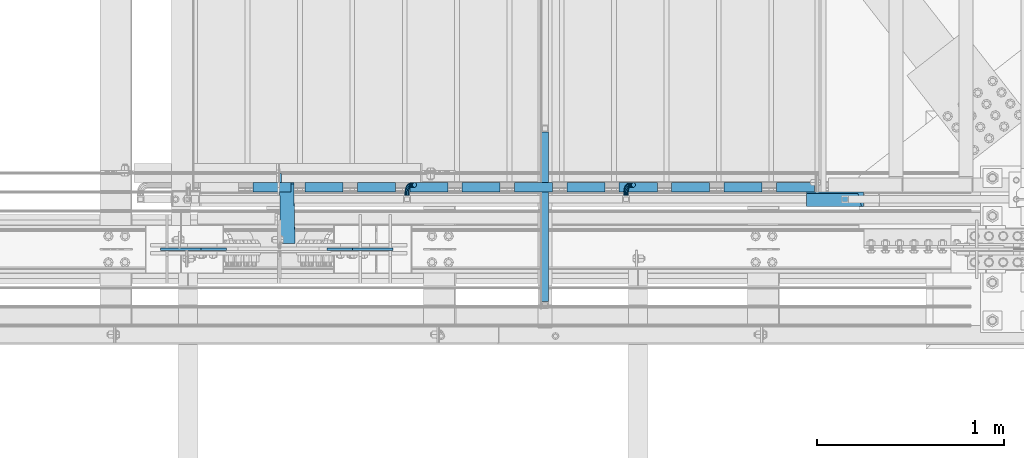
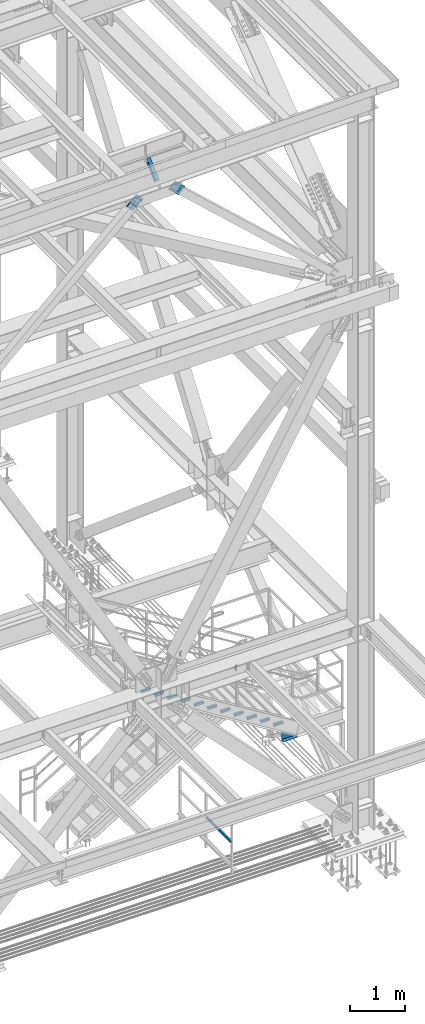
# One storey, part 2552 of 3843: 15 beams, 3 members, 6 elements without a shape of their own.
"""IFC2X3 building model written with IfcOpenShell, lengths in millimetres."""

from ifc_helpers import new_model, si_unit, frame, origin_with_axes, place, context, subcontext, project, spatial, faceted_brep, material, type_object, element, aggregate, save


model = new_model("IFC2X3")

# Units and contexts
model_context = context("Model", 3, precision=1e-05, world=origin_with_axes())
body_context = subcontext(model_context, "Body", "Model", "MODEL_VIEW")
ifc_project = project(units=[si_unit("LENGTHUNIT", "METRE", prefix="MILLI"), si_unit("AREAUNIT", "SQUARE_METRE"), si_unit("VOLUMEUNIT", "CUBIC_METRE"), si_unit("MASSUNIT", "GRAM", prefix="KILO"), si_unit("TIMEUNIT", "SECOND"), si_unit("PLANEANGLEUNIT", "RADIAN"), si_unit("SOLIDANGLEUNIT", "STERADIAN"), si_unit("THERMODYNAMICTEMPERATUREUNIT", "DEGREE_CELSIUS"), si_unit("LUMINOUSINTENSITYUNIT", "LUMEN")], contexts=[model_context])

# Site, building, storey
site_placement = place(None, origin_with_axes())
site = spatial("IfcSite", under=ifc_project, at=site_placement, CompositionType="ELEMENT")
building_placement = place(site_placement, origin_with_axes())
building = spatial("IfcBuilding", under=site, at=building_placement, Name="Undefined", CompositionType="ELEMENT")
storey_placement = place(building_placement, origin_with_axes())
storey = spatial("IfcBuildingStorey", under=building, at=storey_placement, Name="Undefined", CompositionType="ELEMENT", Elevation=0.0)

# Assembly, beam
assembly_1_placement = place(storey_placement, origin_with_axes())
assembly_1 = element("IfcElementAssembly", 1, at=assembly_1_placement, inside=storey, Name="RAIL", AssemblyPlace="NOTDEFINED", PredefinedType="RIGID_FRAME")
ifc_material_1 = material()
beam_type_1 = type_object("IfcBeamType", Name="HSS1-1/2X1-1/2X1/4", PredefinedType="NOTDEFINED")
beam_1_placement = place(assembly_1_placement, frame((82753.1999999998, 15643.225, 31013.4), z_axis=(0.0, 0.0, 1.0), x_axis=(0.0, -1.0, 0.0)))
beam_1 = element("IfcBeam", 2, at=beam_1_placement, type_object=beam_type_1, material=ifc_material_1, Name="RAIL", ObjectType="HSS1-1/2X1-1/2X1/4", context=body_context, shape_type="Brep", body=[
    faceted_brep([(19.0499992350015, 12.6999993299978, -12.6999993299978), (19.0499992350015, -12.6999993299978, -12.6999993299978), (923.92500076501, -12.6999993299978, -12.6999993300014), (923.92500076501, 12.6999993299978, -12.6999993300014), (19.0499992350015, -12.6999993299978, 12.6999993299978), (923.92500076501, -12.6999993299978, 12.6999993300014), (19.0499992350015, 12.6999993299978, 12.6999993299978), (923.92500076501, 12.6999993299978, 12.6999993300014), (19.0499992350015, 19.0499992350015, -19.0499992350015), (19.0499992350015, 19.0499992350015, 19.0499992350015), (923.92500076501, 19.0499992349942, 19.0499992350015), (923.92500076501, 19.0499992349942, -19.0499992350015), (19.0499992350015, -19.0499992350015, 19.0499992350015), (923.92500076501, -19.0499992349942, 19.0499992350015), (19.0499992350015, -19.0499992350015, -19.0499992350015), (923.92500076501, -19.0499992349942, -19.0499992350015)], [[[0, 1, 2, 3]], [[1, 4, 5, 2]], [[4, 6, 7, 5]], [[6, 0, 3, 7]], [[8, 9, 10, 11]], [[9, 12, 13, 10]], [[12, 14, 15, 13]], [[14, 8, 11, 15]], [[13, 15, 11, 10], [5, 7, 3, 2]], [[14, 12, 9, 8], [6, 4, 1, 0]]]),
])
aggregate(assembly_1, [beam_1])

# Assembly, beams
assembly_2_placement = place(storey_placement, origin_with_axes())
assembly_2 = element("IfcElementAssembly", 3, at=assembly_2_placement, inside=storey, Name="STAIR", AssemblyPlace="NOTDEFINED", PredefinedType="RIGID_FRAME")
ifc_material_2 = material(Name="STEEL/A36")
beam_type_2 = type_object("IfcBeamType", Name="L2X2X3/16", PredefinedType="NOTDEFINED")
beam_2_placement = place(assembly_2_placement, frame((81396.2859969491, 15328.9000000191, 34527.1480769223), z_axis=(0.0, 1.0, 0.0), x_axis=(-1.0, 0.0, 0.0)))
beam_2 = element("IfcBeam", 4, at=beam_2_placement, type_object=beam_type_2, material=ifc_material_2, Name="ANGLE", ObjectType="L2X2X3/16", context=body_context, shape_type="Brep", body=[
    faceted_brep([(0.0, 25.4000000000015, -25.4000000000015), (0.0, 25.4000000000015, 25.4000000000015), (203.199999999997, 25.4000000000015, 25.4000000000015), (203.199999999997, 25.4000000000015, -25.4000000000015), (0.0, 20.6375000000007, 25.4000000000015), (203.199999999997, 20.6375000000007, 25.4000000000015), (0.0, 20.6375000000007, -20.6375000000007), (203.199999999997, 20.6375000000007, -20.6375000000007), (0.0, -25.4000000000015, -20.6375000000007), (203.199999999997, -25.4000000000015, -20.6375000000007), (0.0, -25.4000000000015, -25.4000000000015), (203.199999999997, -25.4000000000015, -25.4000000000015)], [[[0, 1, 2, 3]], [[1, 4, 5, 2]], [[4, 6, 7, 5]], [[6, 8, 9, 7]], [[8, 10, 11, 9]], [[10, 0, 3, 11]], [[5, 7, 9, 11, 3, 2]], [[10, 8, 6, 4, 1, 0]]]),
])
beam_3_placement = place(assembly_2_placement, frame((81675.6859969491, 15328.9000000191, 34355.2096153839), z_axis=(0.0, 1.0, 0.0), x_axis=(-1.0, 0.0, 0.0)))
beam_3 = element("IfcBeam", 5, at=beam_3_placement, type_object=beam_type_2, material=ifc_material_2, Name="ANGLE", ObjectType="L2X2X3/16", context=body_context, shape_type="Brep", body=[
    faceted_brep([(0.0, 25.4000000000015, -25.4000000000015), (0.0, 25.4000000000015, 25.4000000000015), (203.199999999997, 25.4000000000015, 25.4000000000015), (203.199999999997, 25.4000000000015, -25.4000000000015), (0.0, 20.6375000000007, 25.4000000000015), (203.199999999997, 20.6375000000007, 25.4000000000015), (0.0, 20.6375000000007, -20.6375000000007), (203.199999999997, 20.6375000000007, -20.6375000000007), (0.0, -25.4000000000015, -20.6375000000007), (203.199999999997, -25.4000000000015, -20.6375000000007), (0.0, -25.4000000000015, -25.4000000000015), (203.199999999997, -25.4000000000015, -25.4000000000015)], [[[0, 1, 2, 3]], [[1, 4, 5, 2]], [[4, 6, 7, 5]], [[6, 8, 9, 7]], [[8, 10, 11, 9]], [[10, 0, 3, 11]], [[5, 7, 9, 11, 3, 2]], [[10, 8, 6, 4, 1, 0]]]),
])
beam_4_placement = place(assembly_2_placement, frame((81955.0859969491, 15328.9000000191, 34183.2711538454), z_axis=(0.0, 1.0, 0.0), x_axis=(-1.0, 0.0, 0.0)))
beam_4 = element("IfcBeam", 6, at=beam_4_placement, type_object=beam_type_2, material=ifc_material_2, Name="ANGLE", ObjectType="L2X2X3/16", context=body_context, shape_type="Brep", body=[
    faceted_brep([(0.0, 25.4000000000015, -25.4000000000015), (0.0, 25.4000000000015, 25.4000000000015), (203.199999999997, 25.4000000000015, 25.4000000000015), (203.199999999997, 25.4000000000015, -25.4000000000015), (0.0, 20.6375000000007, 25.4000000000015), (203.199999999997, 20.6375000000007, 25.4000000000015), (0.0, 20.6375000000007, -20.6375000000007), (203.199999999997, 20.6375000000007, -20.6375000000007), (0.0, -25.4000000000015, -20.6375000000007), (203.199999999997, -25.4000000000015, -20.6375000000007), (0.0, -25.4000000000015, -25.4000000000015), (203.199999999997, -25.4000000000015, -25.4000000000015)], [[[0, 1, 2, 3]], [[1, 4, 5, 2]], [[4, 6, 7, 5]], [[6, 8, 9, 7]], [[8, 10, 11, 9]], [[10, 0, 3, 11]], [[5, 7, 9, 11, 3, 2]], [[10, 8, 6, 4, 1, 0]]]),
])
beam_5_placement = place(assembly_2_placement, frame((82234.4859969491, 15328.9000000191, 34011.3326923069), z_axis=(0.0, 1.0, 0.0), x_axis=(-1.0, 0.0, 0.0)))
beam_5 = element("IfcBeam", 7, at=beam_5_placement, type_object=beam_type_2, material=ifc_material_2, Name="ANGLE", ObjectType="L2X2X3/16", context=body_context, shape_type="Brep", body=[
    faceted_brep([(0.0, 25.4000000000015, -25.4000000000015), (0.0, 25.4000000000015, 25.4000000000015), (203.199999999997, 25.4000000000015, 25.4000000000015), (203.199999999997, 25.4000000000015, -25.4000000000015), (0.0, 20.6375000000007, 25.4000000000015), (203.199999999997, 20.6375000000007, 25.4000000000015), (0.0, 20.6375000000007, -20.6375000000007), (203.199999999997, 20.6375000000007, -20.6375000000007), (0.0, -25.4000000000015, -20.6375000000007), (203.199999999997, -25.4000000000015, -20.6375000000007), (0.0, -25.4000000000015, -25.4000000000015), (203.199999999997, -25.4000000000015, -25.4000000000015)], [[[0, 1, 2, 3]], [[1, 4, 5, 2]], [[4, 6, 7, 5]], [[6, 8, 9, 7]], [[8, 10, 11, 9]], [[10, 0, 3, 11]], [[5, 7, 9, 11, 3, 2]], [[10, 8, 6, 4, 1, 0]]]),
])
beam_6_placement = place(assembly_2_placement, frame((82513.8859969491, 15328.9000000191, 33839.3942307685), z_axis=(0.0, 1.0, 0.0), x_axis=(-1.0, 0.0, 0.0)))
beam_6 = element("IfcBeam", 8, at=beam_6_placement, type_object=beam_type_2, material=ifc_material_2, Name="ANGLE", ObjectType="L2X2X3/16", context=body_context, shape_type="Brep", body=[
    faceted_brep([(0.0, 25.4000000000015, -25.4000000000015), (0.0, 25.4000000000015, 25.4000000000015), (203.199999999997, 25.4000000000015, 25.4000000000015), (203.199999999997, 25.4000000000015, -25.4000000000015), (0.0, 20.6375000000007, 25.4000000000015), (203.199999999997, 20.6375000000007, 25.4000000000015), (0.0, 20.6375000000007, -20.6375000000007), (203.199999999997, 20.6375000000007, -20.6375000000007), (0.0, -25.4000000000015, -20.6375000000007), (203.199999999997, -25.4000000000015, -20.6375000000007), (0.0, -25.4000000000015, -25.4000000000015), (203.199999999997, -25.4000000000015, -25.4000000000015)], [[[0, 1, 2, 3]], [[1, 4, 5, 2]], [[4, 6, 7, 5]], [[6, 8, 9, 7]], [[8, 10, 11, 9]], [[10, 0, 3, 11]], [[5, 7, 9, 11, 3, 2]], [[10, 8, 6, 4, 1, 0]]]),
])
beam_7_placement = place(assembly_2_placement, frame((82793.2859969491, 15328.9000000191, 33667.45576923), z_axis=(0.0, 1.0, 0.0), x_axis=(-1.0, 0.0, 0.0)))
beam_7 = element("IfcBeam", 9, at=beam_7_placement, type_object=beam_type_2, material=ifc_material_2, Name="ANGLE", ObjectType="L2X2X3/16", context=body_context, shape_type="Brep", body=[
    faceted_brep([(0.0, 25.4000000000015, -25.4000000000015), (0.0, 25.4000000000015, 25.4000000000015), (203.199999999997, 25.4000000000015, 25.4000000000015), (203.199999999997, 25.4000000000015, -25.4000000000015), (0.0, 20.6375000000007, 25.4000000000015), (203.199999999997, 20.6375000000007, 25.4000000000015), (0.0, 20.6375000000007, -20.6375000000007), (203.199999999997, 20.6375000000007, -20.6375000000007), (0.0, -25.4000000000015, -20.6375000000007), (203.199999999997, -25.4000000000015, -20.6375000000007), (0.0, -25.4000000000015, -25.4000000000015), (203.199999999997, -25.4000000000015, -25.4000000000015)], [[[0, 1, 2, 3]], [[1, 4, 5, 2]], [[4, 6, 7, 5]], [[6, 8, 9, 7]], [[8, 10, 11, 9]], [[10, 0, 3, 11]], [[5, 7, 9, 11, 3, 2]], [[10, 8, 6, 4, 1, 0]]]),
])
beam_8_placement = place(assembly_2_placement, frame((83072.6859969491, 15328.9000000191, 33495.5173076915), z_axis=(0.0, 1.0, 0.0), x_axis=(-1.0, 0.0, 0.0)))
beam_8 = element("IfcBeam", 10, at=beam_8_placement, type_object=beam_type_2, material=ifc_material_2, Name="ANGLE", ObjectType="L2X2X3/16", context=body_context, shape_type="Brep", body=[
    faceted_brep([(0.0, 25.4000000000015, -25.4000000000015), (0.0, 25.4000000000015, 25.4000000000015), (203.199999999997, 25.4000000000015, 25.4000000000015), (203.199999999997, 25.4000000000015, -25.4000000000015), (0.0, 20.6375000000007, 25.4000000000015), (203.199999999997, 20.6375000000007, 25.4000000000015), (0.0, 20.6375000000007, -20.6375000000007), (203.199999999997, 20.6375000000007, -20.6375000000007), (0.0, -25.4000000000015, -20.6375000000007), (203.199999999997, -25.4000000000015, -20.6375000000007), (0.0, -25.4000000000015, -25.4000000000015), (203.199999999997, -25.4000000000015, -25.4000000000015)], [[[0, 1, 2, 3]], [[1, 4, 5, 2]], [[4, 6, 7, 5]], [[6, 8, 9, 7]], [[8, 10, 11, 9]], [[10, 0, 3, 11]], [[5, 7, 9, 11, 3, 2]], [[10, 8, 6, 4, 1, 0]]]),
])
beam_9_placement = place(assembly_2_placement, frame((83352.0859969491, 15328.9000000191, 33323.5788461531), z_axis=(0.0, 1.0, 0.0), x_axis=(-1.0, 0.0, 0.0)))
beam_9 = element("IfcBeam", 11, at=beam_9_placement, type_object=beam_type_2, material=ifc_material_2, Name="ANGLE", ObjectType="L2X2X3/16", context=body_context, shape_type="Brep", body=[
    faceted_brep([(0.0, 25.4000000000015, -25.4000000000015), (0.0, 25.4000000000015, 25.4000000000015), (203.199999999997, 25.4000000000015, 25.4000000000015), (203.199999999997, 25.4000000000015, -25.4000000000015), (0.0, 20.6375000000007, 25.4000000000015), (203.199999999997, 20.6375000000007, 25.4000000000015), (0.0, 20.6375000000007, -20.6375000000007), (203.199999999997, 20.6375000000007, -20.6375000000007), (0.0, -25.4000000000015, -20.6375000000007), (203.199999999997, -25.4000000000015, -20.6375000000007), (0.0, -25.4000000000015, -25.4000000000015), (203.199999999997, -25.4000000000015, -25.4000000000015)], [[[0, 1, 2, 3]], [[1, 4, 5, 2]], [[4, 6, 7, 5]], [[6, 8, 9, 7]], [[8, 10, 11, 9]], [[10, 0, 3, 11]], [[5, 7, 9, 11, 3, 2]], [[10, 8, 6, 4, 1, 0]]]),
])
beam_10_placement = place(assembly_2_placement, frame((83631.4859969491, 15328.9000000191, 33151.6403846146), z_axis=(0.0, 1.0, 0.0), x_axis=(-1.0, 0.0, 0.0)))
beam_10 = element("IfcBeam", 12, at=beam_10_placement, type_object=beam_type_2, material=ifc_material_2, Name="ANGLE", ObjectType="L2X2X3/16", context=body_context, shape_type="Brep", body=[
    faceted_brep([(0.0, 25.4000000000015, -25.4000000000015), (0.0, 25.4000000000015, 25.4000000000015), (203.199999999997, 25.4000000000015, 25.4000000000015), (203.199999999997, 25.4000000000015, -25.4000000000015), (0.0, 20.6375000000007, 25.4000000000015), (203.199999999997, 20.6375000000007, 25.4000000000015), (0.0, 20.6375000000007, -20.6375000000007), (203.199999999997, 20.6375000000007, -20.6375000000007), (0.0, -25.4000000000015, -20.6375000000007), (203.199999999997, -25.4000000000015, -20.6375000000007), (0.0, -25.4000000000015, -25.4000000000015), (203.199999999997, -25.4000000000015, -25.4000000000015)], [[[0, 1, 2, 3]], [[1, 4, 5, 2]], [[4, 6, 7, 5]], [[6, 8, 9, 7]], [[8, 10, 11, 9]], [[10, 0, 3, 11]], [[5, 7, 9, 11, 3, 2]], [[10, 8, 6, 4, 1, 0]]]),
])
beam_11_placement = place(assembly_2_placement, frame((83910.8859969491, 15328.9000000191, 32979.7019230762), z_axis=(0.0, 1.0, 0.0), x_axis=(-1.0, 0.0, 0.0)))
beam_11 = element("IfcBeam", 13, at=beam_11_placement, type_object=beam_type_2, material=ifc_material_2, Name="ANGLE", ObjectType="L2X2X3/16", context=body_context, shape_type="Brep", body=[
    faceted_brep([(0.0, 25.4000000000015, -25.4000000000015), (0.0, 25.4000000000015, 25.4000000000015), (203.199999999997, 25.4000000000015, 25.4000000000015), (203.199999999997, 25.4000000000015, -25.4000000000015), (0.0, 20.6375000000007, 25.4000000000015), (203.199999999997, 20.6375000000007, 25.4000000000015), (0.0, 20.6375000000007, -20.6375000000007), (203.199999999997, 20.6375000000007, -20.6375000000007), (0.0, -25.4000000000015, -20.6375000000007), (203.199999999997, -25.4000000000015, -20.6375000000007), (0.0, -25.4000000000015, -25.4000000000015), (203.199999999997, -25.4000000000015, -25.4000000000015)], [[[0, 1, 2, 3]], [[1, 4, 5, 2]], [[4, 6, 7, 5]], [[6, 8, 9, 7]], [[8, 10, 11, 9]], [[10, 0, 3, 11]], [[5, 7, 9, 11, 3, 2]], [[10, 8, 6, 4, 1, 0]]]),
])
beam_12_placement = place(assembly_2_placement, frame((84190.2859969491, 15328.9000000191, 32807.7634615377), z_axis=(0.0, 1.0, 0.0), x_axis=(-1.0, 0.0, 0.0)))
beam_12 = element("IfcBeam", 14, at=beam_12_placement, type_object=beam_type_2, material=ifc_material_2, Name="ANGLE", ObjectType="L2X2X3/16", context=body_context, shape_type="Brep", body=[
    faceted_brep([(0.0, 25.4000000000015, -25.4000000000015), (0.0, 25.4000000000015, 25.4000000000015), (203.199999999997, 25.4000000000015, 25.4000000000015), (203.199999999997, 25.4000000000015, -25.4000000000015), (0.0, 20.6375000000007, 25.4000000000015), (203.199999999997, 20.6375000000007, 25.4000000000015), (0.0, 20.6375000000007, -20.6375000000007), (203.199999999997, 20.6375000000007, -20.6375000000007), (0.0, -25.4000000000015, -20.6375000000007), (203.199999999997, -25.4000000000015, -20.6375000000007), (0.0, -25.4000000000015, -25.4000000000015), (203.199999999997, -25.4000000000015, -25.4000000000015)], [[[0, 1, 2, 3]], [[1, 4, 5, 2]], [[4, 6, 7, 5]], [[6, 8, 9, 7]], [[8, 10, 11, 9]], [[10, 0, 3, 11]], [[5, 7, 9, 11, 3, 2]], [[10, 8, 6, 4, 1, 0]]]),
])
beam_type_3 = type_object("IfcBeamType", Name="C12X20.7", PredefinedType="NOTDEFINED")
beam_13_placement = place(assembly_2_placement, frame((84147.3180110544, 15265.3999999998, 32588.1999999948), z_axis=(0.0, 0.0, 1.0), x_axis=(1.0, 0.0, 0.0)))
beam_13 = element("IfcBeam", 15, at=beam_13_placement, type_object=beam_type_3, material=ifc_material_2, Name="STAIR", ObjectType="C12X20.7", context=body_context, shape_type="Brep", body=[
    faceted_brep([(0.0, -38.0999999999985, -146.047460000002), (0.0, -38.0999999999985, -152.400000000001), (304.799999999988, -38.1000000000004, -152.400000000001), (294.477122534838, -38.1000000000004, -146.047460000002), (0.0, 30.1624999999985, -134.6749275), (275.996757284709, 30.1625000000004, -134.6749275), (0.0, 30.1625000000004, 35.1692314024076), (0.0, 38.0999999999985, -152.400000000001), (0.0, 38.1000000000004, 35.1692314024076), (304.799999999988, 38.1000000000004, -152.400000000001)], [[[0, 1, 2, 3]], [[4, 0, 3, 5]], [[4, 5, 6]], [[7, 1, 0, 4, 6, 8]], [[7, 8, 9]], [[1, 7, 9, 2]], [[8, 6, 5, 3, 2, 9]]]),
])
aggregate(assembly_2, [beam_13, beam_2, beam_3, beam_4, beam_5, beam_6, beam_7, beam_8, beam_9, beam_10, beam_11, beam_12])

assembly_3_placement = place(storey_placement, origin_with_axes())
assembly_3 = element("IfcElementAssembly", 16, at=assembly_3_placement, inside=storey, Name="RAIL", AssemblyPlace="NOTDEFINED", PredefinedType="RIGID_FRAME")
beam_type_4 = type_object("IfcBeamType", PredefinedType="NOTDEFINED")
beam_14_placement = place(assembly_3_placement, frame((82016.599999991, 15284.45, 35065.2055271763), z_axis=(0.851658316635874, 0.0, -0.524097425775923), x_axis=(0.0, 1.0, 0.0)))
beam_14 = element("IfcBeam", 17, at=beam_14_placement, type_object=beam_type_4, material=ifc_material_2, Name="BRACKET ARM", context=body_context, shape_type="Brep", body=[
    faceted_brep([(0.0, -12.6999999999971, 0.0), (0.0, -10.9985226280696, -6.34999999999854), (19.0500015258731, -10.9985226280623, -6.34999999999854), (19.0500015258731, -12.6999999999971, -6.33008312433958e-10), (0.0, -6.35000000000582, -10.9985226280623), (19.0500015258731, -6.34999999999854, -10.9985226280623), (0.0, 0.0, -12.6999999999971), (19.0500015258731, 0.0, -12.6999999999971), (0.0, 6.35000000000582, -10.9985226280623), (19.0500015258731, 6.34999999999854, -10.9985226280623), (0.0, 10.9985226280696, -6.34999999999854), (19.0500015258731, 10.9985226280623, -6.34999999999854), (0.0, 12.6999999999971, 0.0), (19.0500015258731, 12.6999999999971, 0.0), (0.0, 10.9985226280696, 6.34999999999854), (19.0500015258731, 10.9985226280623, 6.34999999999854), (0.0, 6.35000000000582, 10.9985226280623), (19.0500015258731, 6.34999999999854, 10.9985226280623), (0.0, 0.0, 12.6999999999971), (19.0500015258731, 0.0, 12.6999999999971), (0.0, -6.35000000000582, 10.9985226280623), (19.0500015258731, -6.34999999999854, 10.9985226280623), (0.0, -10.9985226280696, 6.34999999999854), (19.0500015258731, -10.9985226280623, 6.34999999999854), (38.4903193060891, -8.8330803677236, -3.34694050252438e-10), (37.8391921052389, -7.26112024908798, 6.34999999974389), (36.0602795104642, -2.96644533684594, 10.9985226280041), (33.6302397149266, 2.90018969451194, 12.7000000002226), (31.2001999194181, 8.76682472604443, 10.9985226285644), (29.4212873247307, 13.061499638774, 6.35000000070431), (28.7701601240115, 14.6334597580644, 7.78527464717627e-10), (29.4212873248762, 13.0614996394288, -6.34999999929278), (31.2001999196509, 8.76682472718676, -10.9985226275603), (33.6302397151885, 2.90018969582889, -12.6999999997788), (36.0602795106824, -2.96644533571089, -10.9985226281206), (37.8391921053699, -7.26112024843314, -6.35000000026048), (53.7678987435793, 3.38210125690239, -6.3499999994383), (54.9710249311902, 2.17897506880399, 5.0931703299284e-10), (50.4808968708676, 6.66910312997061, -10.9985226273784), (45.9907688103704, 11.1592311906061, -12.6999999991458), (41.5006407498004, 15.6493592510378, -10.9985226270364), (38.213638876914, 18.9363611235749, -6.34999999884167), (37.0105126890558, 20.1394873109457, 1.20053300634027e-09), (38.2136388766667, 18.9363611228473, 6.35000000115542), (41.5006407493784, 15.6493592497718, 10.9985226290883), (45.9907688098756, 11.1592311891436, 12.7000000008557), (50.4808968704456, 6.66910312870459, 10.9985226287463), (53.7678987433319, 3.38210125617479, 6.35000000055879), (64.4111202489148, 19.3108078951118, -6.34999999821594), (65.9830803677178, 18.6596806939051, 1.77533365786076e-09), (60.1164453365491, 21.0897204901557, -10.9985226262725), (54.2498103051475, 23.5197602857806, -12.6999999981927), (48.3831752736587, 25.9498000811873, -10.9985226262434), (44.0885003610601, 27.7287126756128, -6.34999999817228), (42.516540241937, 28.3798398759754, 1.83354131877422e-09), (44.08850036074, 27.7287126747688, 6.35000000183209), (48.3831752731057, 25.9498000797321, 10.9985226298813), (54.2498103045073, 23.5197602840999, 12.7000000018088), (60.1164453359961, 21.0897204886933, 10.9985226298522), (64.4111202485947, 19.3108078942678, 6.35000000178115), (68.1485226282239, 38.0999984746086, -6.3499999967753), (69.8499999999913, 38.0999984741211, 2.92493496090174e-09), (63.500000000291, 38.0999984749651, -10.9985226249628), (57.1500000003434, 38.0999984750961, -12.6999999970722), (50.8000000002939, 38.0999984749651, -10.998522625312), (46.1514773720992, 38.0999984746086, -6.34999999737192), (44.4499999999971, 38.0999984741211, 2.58296495303512e-09), (46.1514773717645, 38.0999984736336, 6.35000000262517), (50.7999999996973, 38.0999984732771, 10.9985226308127), (57.1499999996449, 38.0999984731461, 12.700000002922), (63.4999999996944, 38.0999984732771, 10.9985226311619), (68.1485226278892, 38.0999984736336, 6.35000000322179), (68.1485226280638, 76.2000000002372, -6.34999999414867), (69.8499999999913, 76.199999999757, 5.84986992180347e-09), (63.5, 76.200000000601, -10.9985226222125), (57.1499999999942, 76.2000000007247, -12.6999999941472), (50.7999999999884, 76.200000000601, -10.9985226222125), (46.1514773719246, 76.2000000002372, -6.34999999414867), (44.4499999999971, 76.199999999757, 5.84986992180347e-09), (46.1514773719246, 76.1999999992695, 6.35000000584841), (50.7999999999884, 76.1999999989057, 10.9985226339122), (57.1499999999942, 76.199999998782, 12.700000005847), (63.5, 76.1999999989057, 10.9985226339122), (68.1485226280638, 76.1999999992695, 6.35000000584841)], [[[0, 1, 2, 3]], [[1, 4, 5, 2]], [[4, 6, 7, 5]], [[6, 8, 9, 7]], [[8, 10, 11, 9]], [[10, 12, 13, 11]], [[12, 14, 15, 13]], [[14, 16, 17, 15]], [[16, 18, 19, 17]], [[18, 20, 21, 19]], [[20, 22, 23, 21]], [[22, 0, 3, 23]], [[22, 20, 18, 16, 14, 12, 10, 8, 6, 4, 1, 0]], [[23, 3, 24, 25]], [[21, 23, 25, 26]], [[19, 21, 26, 27]], [[17, 19, 27, 28]], [[15, 17, 28, 29]], [[13, 15, 29, 30]], [[11, 13, 30, 31]], [[9, 11, 31, 32]], [[7, 9, 32, 33]], [[5, 7, 33, 34]], [[2, 5, 34, 35]], [[3, 2, 35, 24]], [[35, 36, 37, 24]], [[34, 38, 36, 35]], [[33, 39, 38, 34]], [[32, 40, 39, 33]], [[31, 41, 40, 32]], [[30, 42, 41, 31]], [[29, 43, 42, 30]], [[28, 44, 43, 29]], [[27, 45, 44, 28]], [[26, 46, 45, 27]], [[25, 47, 46, 26]], [[24, 37, 47, 25]], [[36, 48, 49, 37]], [[38, 50, 48, 36]], [[39, 51, 50, 38]], [[40, 52, 51, 39]], [[41, 53, 52, 40]], [[42, 54, 53, 41]], [[43, 55, 54, 42]], [[44, 56, 55, 43]], [[45, 57, 56, 44]], [[46, 58, 57, 45]], [[47, 59, 58, 46]], [[37, 49, 59, 47]], [[48, 60, 61, 49]], [[50, 62, 60, 48]], [[51, 63, 62, 50]], [[52, 64, 63, 51]], [[53, 65, 64, 52]], [[54, 66, 65, 53]], [[55, 67, 66, 54]], [[56, 68, 67, 55]], [[57, 69, 68, 56]], [[58, 70, 69, 57]], [[59, 71, 70, 58]], [[49, 61, 71, 59]], [[61, 60, 72, 73]], [[60, 62, 74, 72]], [[62, 63, 75, 74]], [[63, 64, 76, 75]], [[64, 65, 77, 76]], [[65, 66, 78, 77]], [[66, 67, 79, 78]], [[67, 68, 80, 79]], [[68, 69, 81, 80]], [[69, 70, 82, 81]], [[70, 71, 83, 82]], [[71, 61, 73, 83]], [[74, 75, 76, 77, 78, 79, 80, 81, 82, 83, 73, 72]]]),
])
beam_15_placement = place(assembly_3_placement, frame((83184.9999999817, 15284.45, 34346.1901423555), z_axis=(0.851658316635874, 0.0, -0.524097425775923), x_axis=(0.0, 1.0, 0.0)))
beam_15 = element("IfcBeam", 18, at=beam_15_placement, type_object=beam_type_4, material=ifc_material_2, Name="BRACKET ARM", context=body_context, shape_type="Brep", body=[
    faceted_brep([(0.0, -12.6999999999971, 0.0), (0.0, -10.9985226280696, -6.34999999999854), (19.0500015258731, -10.9985226280623, -6.34999999999854), (19.0500015258731, -12.6999999999971, -6.33008312433958e-10), (0.0, -6.35000000000582, -10.9985226280623), (19.0500015258731, -6.34999999999854, -10.9985226280623), (0.0, 0.0, -12.6999999999971), (19.0500015258731, 0.0, -12.6999999999971), (0.0, 6.35000000000582, -10.9985226280623), (19.0500015258731, 6.34999999999854, -10.9985226280623), (0.0, 10.9985226280696, -6.34999999999854), (19.0500015258731, 10.9985226280623, -6.34999999999854), (0.0, 12.6999999999971, 0.0), (19.0500015258731, 12.6999999999971, 0.0), (0.0, 10.9985226280696, 6.34999999999854), (19.0500015258731, 10.9985226280623, 6.34999999999854), (0.0, 6.35000000000582, 10.9985226280623), (19.0500015258731, 6.34999999999854, 10.9985226280623), (0.0, 0.0, 12.6999999999971), (19.0500015258731, 0.0, 12.6999999999971), (0.0, -6.35000000000582, 10.9985226280623), (19.0500015258731, -6.34999999999854, 10.9985226280623), (0.0, -10.9985226280696, 6.34999999999854), (19.0500015258731, -10.9985226280623, 6.34999999999854), (38.4903193060891, -8.8330803677236, -3.34694050252438e-10), (37.8391921052389, -7.26112024908798, 6.34999999974389), (36.0602795104642, -2.96644533684594, 10.9985226280041), (33.6302397149266, 2.90018969451194, 12.7000000002226), (31.2001999194181, 8.76682472604443, 10.9985226285644), (29.4212873247307, 13.061499638774, 6.35000000070431), (28.7701601240115, 14.6334597580644, 7.78527464717627e-10), (29.4212873248762, 13.0614996394288, -6.34999999929278), (31.2001999196509, 8.76682472718676, -10.9985226275603), (33.6302397151885, 2.90018969582889, -12.6999999997788), (36.0602795106824, -2.96644533571089, -10.9985226281206), (37.8391921053699, -7.26112024843314, -6.35000000026048), (53.7678987435793, 3.38210125690239, -6.3499999994383), (54.9710249311902, 2.17897506880399, 5.0931703299284e-10), (50.4808968708676, 6.66910312997061, -10.9985226273784), (45.9907688103704, 11.1592311906061, -12.6999999991458), (41.5006407498004, 15.6493592510378, -10.9985226270364), (38.213638876914, 18.9363611235749, -6.34999999884167), (37.0105126890558, 20.1394873109457, 1.20053300634027e-09), (38.2136388766667, 18.9363611228473, 6.35000000115542), (41.5006407493784, 15.6493592497718, 10.9985226290883), (45.9907688098756, 11.1592311891436, 12.7000000008557), (50.4808968704456, 6.66910312870459, 10.9985226287463), (53.7678987433319, 3.38210125617479, 6.35000000055879), (64.4111202489148, 19.3108078951118, -6.34999999821594), (65.9830803677178, 18.6596806939051, 1.77533365786076e-09), (60.1164453365491, 21.0897204901557, -10.9985226262725), (54.2498103051475, 23.5197602857806, -12.6999999981927), (48.3831752736587, 25.9498000811873, -10.9985226262434), (44.0885003610601, 27.7287126756128, -6.34999999817228), (42.516540241937, 28.3798398759754, 1.83354131877422e-09), (44.08850036074, 27.7287126747688, 6.35000000183209), (48.3831752731057, 25.9498000797321, 10.9985226298813), (54.2498103045073, 23.5197602840999, 12.7000000018088), (60.1164453359961, 21.0897204886933, 10.9985226298522), (64.4111202485947, 19.3108078942678, 6.35000000178115), (68.1485226282239, 38.0999984746086, -6.3499999967753), (69.8499999999913, 38.0999984741211, 2.92493496090174e-09), (63.500000000291, 38.0999984749651, -10.9985226249628), (57.1500000003434, 38.0999984750961, -12.6999999970722), (50.8000000002939, 38.0999984749651, -10.998522625312), (46.1514773720992, 38.0999984746086, -6.34999999737192), (44.4499999999971, 38.0999984741211, 2.58296495303512e-09), (46.1514773717645, 38.0999984736336, 6.35000000262517), (50.7999999996973, 38.0999984732771, 10.9985226308127), (57.1499999996449, 38.0999984731461, 12.700000002922), (63.4999999996944, 38.0999984732771, 10.9985226311619), (68.1485226278892, 38.0999984736336, 6.35000000322179), (68.1485226280638, 76.2000000002372, -6.34999999414867), (69.8499999999913, 76.199999999757, 5.84986992180347e-09), (63.5, 76.200000000601, -10.9985226222125), (57.1499999999942, 76.2000000007247, -12.6999999941472), (50.7999999999884, 76.200000000601, -10.9985226222125), (46.1514773719246, 76.2000000002372, -6.34999999414867), (44.4499999999971, 76.199999999757, 5.84986992180347e-09), (46.1514773719246, 76.1999999992695, 6.35000000584841), (50.7999999999884, 76.1999999989057, 10.9985226339122), (57.1499999999942, 76.199999998782, 12.700000005847), (63.5, 76.1999999989057, 10.9985226339122), (68.1485226280638, 76.1999999992695, 6.35000000584841)], [[[0, 1, 2, 3]], [[1, 4, 5, 2]], [[4, 6, 7, 5]], [[6, 8, 9, 7]], [[8, 10, 11, 9]], [[10, 12, 13, 11]], [[12, 14, 15, 13]], [[14, 16, 17, 15]], [[16, 18, 19, 17]], [[18, 20, 21, 19]], [[20, 22, 23, 21]], [[22, 0, 3, 23]], [[22, 20, 18, 16, 14, 12, 10, 8, 6, 4, 1, 0]], [[23, 3, 24, 25]], [[21, 23, 25, 26]], [[19, 21, 26, 27]], [[17, 19, 27, 28]], [[15, 17, 28, 29]], [[13, 15, 29, 30]], [[11, 13, 30, 31]], [[9, 11, 31, 32]], [[7, 9, 32, 33]], [[5, 7, 33, 34]], [[2, 5, 34, 35]], [[3, 2, 35, 24]], [[35, 36, 37, 24]], [[34, 38, 36, 35]], [[33, 39, 38, 34]], [[32, 40, 39, 33]], [[31, 41, 40, 32]], [[30, 42, 41, 31]], [[29, 43, 42, 30]], [[28, 44, 43, 29]], [[27, 45, 44, 28]], [[26, 46, 45, 27]], [[25, 47, 46, 26]], [[24, 37, 47, 25]], [[36, 48, 49, 37]], [[38, 50, 48, 36]], [[39, 51, 50, 38]], [[40, 52, 51, 39]], [[41, 53, 52, 40]], [[42, 54, 53, 41]], [[43, 55, 54, 42]], [[44, 56, 55, 43]], [[45, 57, 56, 44]], [[46, 58, 57, 45]], [[47, 59, 58, 46]], [[37, 49, 59, 47]], [[48, 60, 61, 49]], [[50, 62, 60, 48]], [[51, 63, 62, 50]], [[52, 64, 63, 51]], [[53, 65, 64, 52]], [[54, 66, 65, 53]], [[55, 67, 66, 54]], [[56, 68, 67, 55]], [[57, 69, 68, 56]], [[58, 70, 69, 57]], [[59, 71, 70, 58]], [[49, 61, 71, 59]], [[61, 60, 72, 73]], [[60, 62, 74, 72]], [[62, 63, 75, 74]], [[63, 64, 76, 75]], [[64, 65, 77, 76]], [[65, 66, 78, 77]], [[66, 67, 79, 78]], [[67, 68, 80, 79]], [[68, 69, 81, 80]], [[69, 70, 82, 81]], [[70, 71, 83, 82]], [[71, 61, 73, 83]], [[74, 75, 76, 77, 78, 79, 80, 81, 82, 83, 73, 72]]]),
])
aggregate(assembly_3, [beam_14, beam_15])

# Assembly, member
assembly_4_placement = place(storey_placement, origin_with_axes())
assembly_4 = element("IfcElementAssembly", 19, at=assembly_4_placement, inside=storey, AssemblyPlace="NOTDEFINED", PredefinedType="RIGID_FRAME")
ifc_material_3 = material(Name="STEEL/A572-50")
member_type_1 = type_object("IfcMemberType", PredefinedType="NOTDEFINED")
member_1_placement = place(assembly_4_placement, frame((81657.8451584721, 14998.6999999426, 45857.3131936302), z_axis=(0.675885212782435, 0.0, 0.737006905762791), x_axis=(0.737006905762768, 0.0, -0.67588521278246)))
member_1 = element("IfcMember", 20, at=member_1_placement, type_object=member_type_1, material=ifc_material_3, Name="PLATE", context=body_context, shape_type="Brep", body=[
    faceted_brep([(1.74622982740402e-10, 6.35000000000582, -101.600000000195), (-1.67347025126219e-10, 6.35000000000582, 101.600000000151), (292.1000000028, 6.35000000000582, 101.600000000661), (292.100000003156, 6.35000000000582, -101.599999999686), (-1.67347025126219e-10, -6.35000000000582, 101.600000000151), (292.1000000028, -6.35000000000582, 101.600000000661), (1.74622982740402e-10, -6.35000000000582, -101.600000000195), (292.100000003156, -6.35000000000582, -101.599999999686)], [[[0, 1, 2, 3]], [[1, 4, 5, 2]], [[4, 6, 7, 5]], [[6, 0, 3, 7]], [[5, 7, 3, 2]], [[6, 4, 1, 0]]]),
])
aggregate(assembly_4, [member_1])

assembly_5_placement = place(storey_placement, origin_with_axes())
assembly_5 = element("IfcElementAssembly", 21, at=assembly_5_placement, inside=storey, AssemblyPlace="NOTDEFINED", PredefinedType="RIGID_FRAME")
member_2_placement = place(assembly_5_placement, frame((80985.0653129844, 14998.6999999426, 45840.1736272158), z_axis=(0.675885212782439, 0.0, -0.737006905762787), x_axis=(-0.73700690576278, 0.0, -0.675885212782446)))
member_2 = element("IfcMember", 22, at=member_2_placement, type_object=member_type_1, material=ifc_material_3, Name="PLATE", context=body_context, shape_type="Brep", body=[
    faceted_brep([(1.74622982740402e-10, 6.35000000000582, -101.600000000195), (-1.67347025126219e-10, 6.35000000000582, 101.600000000151), (292.1000000028, 6.35000000000582, 101.600000000661), (292.100000003156, 6.35000000000582, -101.599999999686), (-1.67347025126219e-10, -6.35000000000582, 101.600000000151), (292.1000000028, -6.35000000000582, 101.600000000661), (1.74622982740402e-10, -6.35000000000582, -101.600000000195), (292.100000003156, -6.35000000000582, -101.599999999686)], [[[0, 1, 2, 3]], [[1, 4, 5, 2]], [[4, 6, 7, 5]], [[6, 0, 3, 7]], [[5, 7, 3, 2]], [[6, 4, 1, 0]]]),
])
aggregate(assembly_5, [member_2])

assembly_6_placement = place(storey_placement, origin_with_axes())
assembly_6 = element("IfcElementAssembly", 23, at=assembly_6_placement, inside=storey, Name="ANGLE", AssemblyPlace="NOTDEFINED", PredefinedType="RIGID_FRAME")
member_type_2 = type_object("IfcMemberType", Name="L3X3X3/8", PredefinedType="NOTDEFINED")
member_3_placement = place(assembly_6_placement, frame((81370.3603023814, 15570.2884149004, 46521.7799966723), z_axis=(0.0149567919991071, 0.70710678095505, -0.706948579955064), x_axis=(0.0149567919892506, -0.707106781418042, -0.706948579492178)))
member_3 = element("IfcMember", 24, at=member_3_placement, type_object=member_type_2, material=ifc_material_3, Name="ANGLE", ObjectType="L3X3X3/8", context=body_context, shape_type="Brep", body=[
    faceted_brep([(276.741870175065, 38.0999999989435, -38.0999999994419), (276.741870179554, -38.1000000005151, -38.0999999994856), (276.741870185811, -38.1000000005006, -28.5749999994769), (276.74187018189, 28.5749999990367, -28.5749999994441), (276.74187022572, 28.5749999991822, 38.1000000005624), (276.74187022516, 38.0999999991036, 38.1000000005697), (727.591870170465, 28.5749999980617, 38.1000000014537), (727.591870169912, 38.0999999979686, 38.100000001461), (727.591870173688, 38.0999999978085, -38.0999999985506), (727.59187017817, -38.1000000016502, -38.099999998587), (727.591870177697, -38.1000000016211, -28.5749999985856), (727.591870173776, 28.5749999978871, -28.5749999985528)], [[[0, 1, 2, 3, 4, 5]], [[5, 4, 6, 7]], [[0, 5, 7, 8]], [[1, 0, 8, 9]], [[2, 1, 9, 10]], [[3, 2, 10, 11]], [[4, 3, 11, 6]], [[10, 9, 8, 7, 6, 11]]]),
])
aggregate(assembly_6, [member_3])

save(model, "model.ifc")
